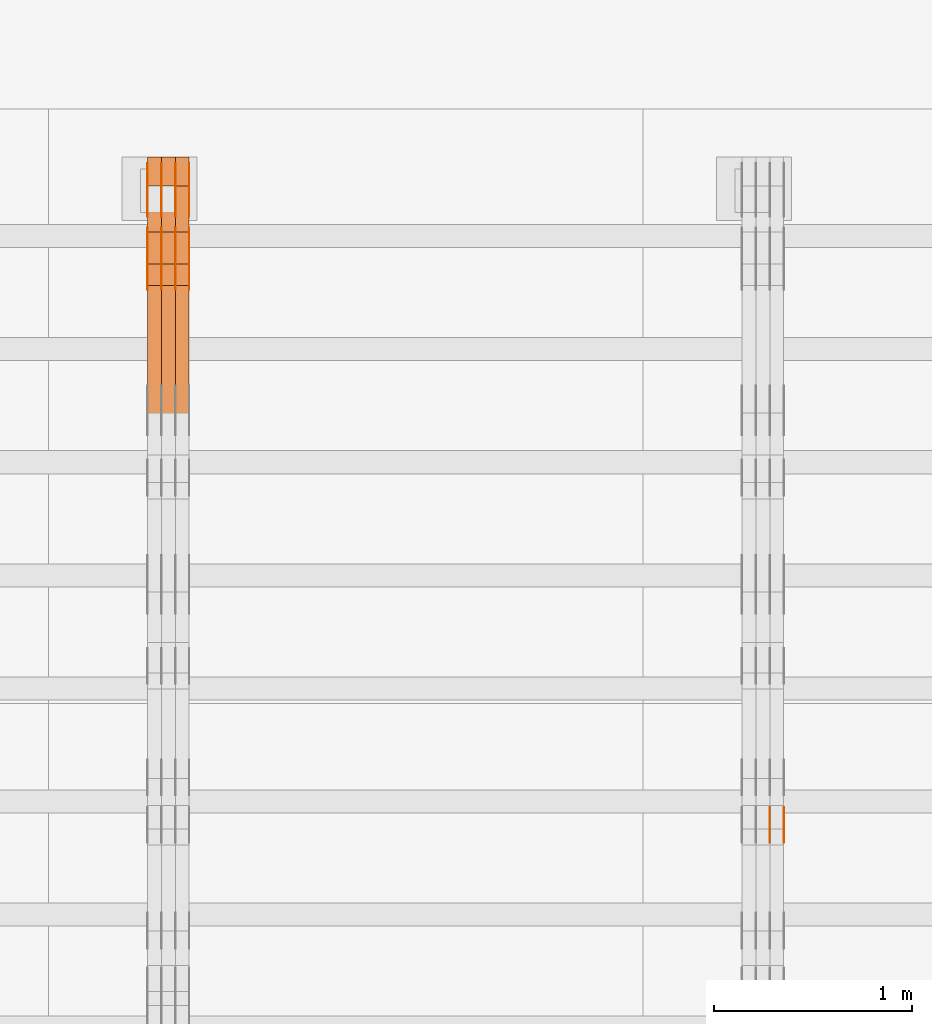
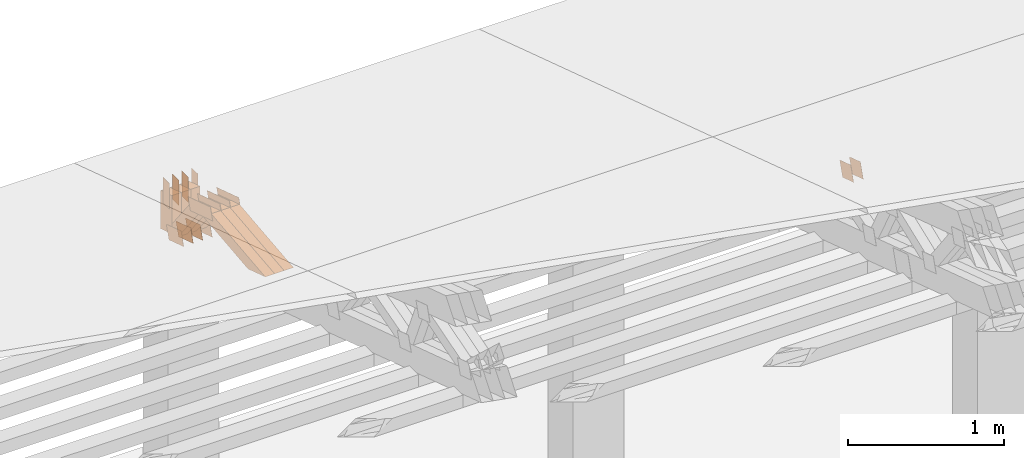
# One storey, part 239 of 385: 29 proxies.
"""IFC2X3 building model written with IfcOpenShell, lengths in millimetres."""

from ifc_helpers import new_model, entity, si_unit, converted_unit, derived_unit, direction, frame, frame_2d, origin, place, context, subcontext, project, spatial, polyline, rectangle, outline, extrude, source, transform, mapped, material, type_object, type_shapes, element, save


model = new_model("IFC2X3")

# Units and contexts
model_context = context("Model", 3, precision=0.01, world=origin(), true_north=direction((6.12303176911189e-17, 1.0)))
body_context = subcontext(model_context, "Body", "Model", "MODEL_VIEW")
ifc_project = project(units=[si_unit("LENGTHUNIT", "METRE", prefix="MILLI"), si_unit("AREAUNIT", "SQUARE_METRE"), si_unit("VOLUMEUNIT", "CUBIC_METRE"), converted_unit("PLANEANGLEUNIT", "DEGREE", entity("IfcRatioMeasure", 0.0174532925199433), si_unit("PLANEANGLEUNIT", "RADIAN"), dimensions=[0, 0, 0, 0, 0, 0, 0]), si_unit("MASSUNIT", "GRAM", prefix="KILO"), derived_unit("MASSDENSITYUNIT", [(si_unit("MASSUNIT", "GRAM", prefix="KILO"), 1), (si_unit("LENGTHUNIT", "METRE"), -3)]), si_unit("TIMEUNIT", "SECOND"), si_unit("FREQUENCYUNIT", "HERTZ"), si_unit("THERMODYNAMICTEMPERATUREUNIT", "DEGREE_CELSIUS"), derived_unit("THERMALTRANSMITTANCEUNIT", [(si_unit("MASSUNIT", "GRAM", prefix="KILO"), 1), (si_unit("THERMODYNAMICTEMPERATUREUNIT", "KELVIN"), -1), (si_unit("TIMEUNIT", "SECOND"), -3)]), derived_unit("VOLUMETRICFLOWRATEUNIT", [(si_unit("LENGTHUNIT", "METRE"), 3), (si_unit("TIMEUNIT", "SECOND"), -1)]), si_unit("ELECTRICCURRENTUNIT", "AMPERE"), si_unit("ELECTRICVOLTAGEUNIT", "VOLT"), si_unit("POWERUNIT", "WATT"), si_unit("FORCEUNIT", "NEWTON", prefix="KILO"), si_unit("ILLUMINANCEUNIT", "LUX"), si_unit("LUMINOUSFLUXUNIT", "LUMEN"), si_unit("LUMINOUSINTENSITYUNIT", "CANDELA"), derived_unit("USERDEFINED", [(si_unit("MASSUNIT", "GRAM", prefix="KILO"), -1), (si_unit("LENGTHUNIT", "METRE"), -2), (si_unit("TIMEUNIT", "SECOND"), 3), (si_unit("LUMINOUSFLUXUNIT", "LUMEN"), 1)]), derived_unit("LINEARVELOCITYUNIT", [(si_unit("LENGTHUNIT", "METRE"), 1), (si_unit("TIMEUNIT", "SECOND"), -1)]), si_unit("PRESSUREUNIT", "PASCAL"), derived_unit("USERDEFINED", [(si_unit("LENGTHUNIT", "METRE"), -2), (si_unit("MASSUNIT", "GRAM", prefix="KILO"), 1), (si_unit("TIMEUNIT", "SECOND"), -2)])], contexts=[model_context])

# Site, building, storey
site_placement = place(None, origin())
site = spatial("IfcSite", under=ifc_project, at=site_placement, CompositionType="ELEMENT")
building_placement = place(site_placement, origin())
building = spatial("IfcBuilding", under=site, at=building_placement, CompositionType="ELEMENT")
storey_placement = place(building_placement, origin())
storey = spatial("IfcBuildingStorey", under=building, at=storey_placement, Name="Default", CompositionType="ELEMENT", Elevation=0.0)

# Proxies
ifc_material_1 = material(Name="IfcSurfaceStyle #368646")
building_element_proxy_type_1 = type_object("IfcBuildingElementProxyType", PredefinedType="NOTDEFINED", material=ifc_material_1)
shared_shape_1 = source(origin(), body_context, "Body", "SweptSolid", [
    extrude(outline(polyline([(-74.9998888504569, -59.9999264677525), (74.999884859074, -59.9999264677525), (74.9998699895559, 59.9999264677525), (-74.999865998173, 59.9999264677525), (-74.9998888504569, -59.9999264677525)])), frame((74.9999170714918, 60.0000016373507, 0.0), z_axis=(0.0, 0.0, 1.0), x_axis=(-1.0, 0.0, 0.0)), (0.0, 0.0, 1.0), 1.3),
])
type_shapes(building_element_proxy_type_1, [shared_shape_1])
proxy_1_placement = place(building_placement, frame((30386.3, 23182.5962361838, 1409.76695322432), z_axis=(-1.0, 0.0, 0.0), x_axis=(0.0, -0.951056516295154, 0.309016994374948)))
element("IfcBuildingElementProxy", 1, at=proxy_1_placement, inside=storey, type_object=building_element_proxy_type_1, material=ifc_material_1, context=body_context, shape_type="MappedRepresentation", body=[
    mapped(shared_shape_1, transform((0.0, 0.0, 0.0), scale=1.0)),
])
ifc_material_2 = material(Name="IfcSurfaceStyle #368589")
building_element_proxy_type_2 = type_object("IfcBuildingElementProxyType", PredefinedType="NOTDEFINED", material=ifc_material_2)
shared_shape_2 = source(origin(), body_context, "Body", "SweptSolid", [
    extrude(outline(polyline([(-74.9998888504569, -59.9999264677525), (74.999884859074, -59.9999264677525), (74.9998699895559, 59.9999264677525), (-74.999865998173, 59.9999264677525), (-74.9998888504569, -59.9999264677525)])), frame((74.9999170714918, 60.0000016373507, 0.0), z_axis=(0.0, 0.0, 1.0), x_axis=(-1.0, 0.0, 0.0)), (0.0, 0.0, 1.0), 1.3),
])
type_shapes(building_element_proxy_type_2, [shared_shape_2])
proxy_2_placement = place(building_placement, frame((30315.0, 23182.5962361838, 1409.76695322432), z_axis=(-1.0, 0.0, 0.0), x_axis=(0.0, -0.951056516295154, 0.309016994374948)))
element("IfcBuildingElementProxy", 2, at=proxy_2_placement, inside=storey, type_object=building_element_proxy_type_2, material=ifc_material_2, context=body_context, shape_type="MappedRepresentation", body=[
    mapped(shared_shape_2, transform((0.0, 0.0, 0.0), scale=1.0)),
])
ifc_material_3 = material(Name="IfcSurfaceStyle #343790")
building_element_proxy_type_3 = type_object("IfcBuildingElementProxyType", PredefinedType="NOTDEFINED", material=ifc_material_3)
shared_shape_3 = source(origin(), body_context, "Body", "SweptSolid", [
    extrude(outline(polyline([(-100.000024997547, -54.0000105875654), (100.000088940899, -54.0000105875654), (99.9999100805868, 54.0000105875654), (-99.9999740239394, 54.0000105875654), (-100.000024997547, -54.0000105875654)])), frame((100.000088940899, 54.0000474633838, 0.0), z_axis=(0.0, 0.0, 1.0), x_axis=(-1.0, 0.0, 0.0)), (0.0, 0.0, 1.0), 1.3),
])
type_shapes(building_element_proxy_type_3, [shared_shape_3])
proxy_3_placement = place(building_placement, frame((27386.3, 26390.6212638563, 73.3227520411355), z_axis=(-1.0, 0.0, 0.0), x_axis=(0.0, -0.951056516295124, 0.309016994375039)))
element("IfcBuildingElementProxy", 3, at=proxy_3_placement, inside=storey, type_object=building_element_proxy_type_3, material=ifc_material_3, context=body_context, shape_type="MappedRepresentation", body=[
    mapped(shared_shape_3, transform((0.0, 0.0, 0.0), scale=1.0)),
])
ifc_material_4 = material(Name="IfcSurfaceStyle #343733")
building_element_proxy_type_4 = type_object("IfcBuildingElementProxyType", PredefinedType="NOTDEFINED", material=ifc_material_4)
shared_shape_4 = source(origin(), body_context, "Body", "SweptSolid", [
    extrude(outline(polyline([(-100.000024997547, -54.0000105875654), (100.000088940899, -54.0000105875654), (99.9999100805868, 54.0000105875654), (-99.9999740239394, 54.0000105875654), (-100.000024997547, -54.0000105875654)])), frame((100.000088940899, 54.0000474633838, 0.0), z_axis=(0.0, 0.0, 1.0), x_axis=(-1.0, 0.0, 0.0)), (0.0, 0.0, 1.0), 1.3),
])
type_shapes(building_element_proxy_type_4, [shared_shape_4])
proxy_4_placement = place(building_placement, frame((27315.0, 26390.6212638563, 73.3227520411355), z_axis=(-1.0, 0.0, 0.0), x_axis=(0.0, -0.951056516295124, 0.309016994375039)))
element("IfcBuildingElementProxy", 4, at=proxy_4_placement, inside=storey, type_object=building_element_proxy_type_4, material=ifc_material_4, context=body_context, shape_type="MappedRepresentation", body=[
    mapped(shared_shape_4, transform((0.0, 0.0, 0.0), scale=1.0)),
])
ifc_material_5 = material(Name="IfcSurfaceStyle #343676")
building_element_proxy_type_5 = type_object("IfcBuildingElementProxyType", PredefinedType="NOTDEFINED", material=ifc_material_5)
shared_shape_5 = source(origin(), body_context, "Body", "SweptSolid", [
    extrude(outline(polyline([(-100.000024997547, -54.0000105875654), (100.000088940899, -54.0000105875654), (99.9999100805868, 54.0000105875654), (-99.9999740239394, 54.0000105875654), (-100.000024997547, -54.0000105875654)])), frame((100.000088940899, 54.0000474633838, 0.0), z_axis=(0.0, 0.0, 1.0), x_axis=(-1.0, 0.0, 0.0)), (0.0, 0.0, 1.0), 1.3),
])
type_shapes(building_element_proxy_type_5, [shared_shape_5])
proxy_5_placement = place(building_placement, frame((27316.3, 26390.6212638563, 73.3227520411355), z_axis=(-1.0, 0.0, 0.0), x_axis=(0.0, -0.951056516295124, 0.309016994375039)))
element("IfcBuildingElementProxy", 5, at=proxy_5_placement, inside=storey, type_object=building_element_proxy_type_5, material=ifc_material_5, context=body_context, shape_type="MappedRepresentation", body=[
    mapped(shared_shape_5, transform((0.0, 0.0, 0.0), scale=1.0)),
])
ifc_material_6 = material(Name="IfcSurfaceStyle #343619")
building_element_proxy_type_6 = type_object("IfcBuildingElementProxyType", PredefinedType="NOTDEFINED", material=ifc_material_6)
shared_shape_6 = source(origin(), body_context, "Body", "SweptSolid", [
    extrude(outline(polyline([(-100.000024997547, -54.0000105875654), (100.000088940899, -54.0000105875654), (99.9999100805868, 54.0000105875654), (-99.9999740239394, 54.0000105875654), (-100.000024997547, -54.0000105875654)])), frame((100.000088940899, 54.0000474633838, 0.0), z_axis=(0.0, 0.0, 1.0), x_axis=(-1.0, 0.0, 0.0)), (0.0, 0.0, 1.0), 1.29999999999998),
])
type_shapes(building_element_proxy_type_6, [shared_shape_6])
proxy_6_placement = place(building_placement, frame((27245.0, 26390.6212638563, 73.3227520411355), z_axis=(-1.0, 0.0, 0.0), x_axis=(0.0, -0.951056516295124, 0.309016994375039)))
element("IfcBuildingElementProxy", 6, at=proxy_6_placement, inside=storey, type_object=building_element_proxy_type_6, material=ifc_material_6, context=body_context, shape_type="MappedRepresentation", body=[
    mapped(shared_shape_6, transform((0.0, 0.0, 0.0), scale=1.0)),
])
ifc_material_7 = material(Name="IfcSurfaceStyle #343562")
building_element_proxy_type_7 = type_object("IfcBuildingElementProxyType", PredefinedType="NOTDEFINED", material=ifc_material_7)
shared_shape_7 = source(origin(), body_context, "Body", "SweptSolid", [
    extrude(outline(polyline([(-100.000024997547, -54.0000105875654), (100.000088940899, -54.0000105875654), (99.9999100805868, 54.0000105875654), (-99.9999740239394, 54.0000105875654), (-100.000024997547, -54.0000105875654)])), frame((100.000088940899, 54.0000474633838, 0.0), z_axis=(0.0, 0.0, 1.0), x_axis=(-1.0, 0.0, 0.0)), (0.0, 0.0, 1.0), 1.29999999999998),
])
type_shapes(building_element_proxy_type_7, [shared_shape_7])
proxy_7_placement = place(building_placement, frame((27246.3, 26390.6212638563, 73.3227520411355), z_axis=(-1.0, 0.0, 0.0), x_axis=(0.0, -0.951056516295124, 0.309016994375039)))
element("IfcBuildingElementProxy", 7, at=proxy_7_placement, inside=storey, type_object=building_element_proxy_type_7, material=ifc_material_7, context=body_context, shape_type="MappedRepresentation", body=[
    mapped(shared_shape_7, transform((0.0, 0.0, 0.0), scale=1.0)),
])
ifc_material_8 = material(Name="IfcSurfaceStyle #343505")
building_element_proxy_type_8 = type_object("IfcBuildingElementProxyType", PredefinedType="NOTDEFINED", material=ifc_material_8)
shared_shape_8 = source(origin(), body_context, "Body", "SweptSolid", [
    extrude(outline(polyline([(-100.000024997547, -54.0000105875654), (100.000088940899, -54.0000105875654), (99.9999100805868, 54.0000105875654), (-99.9999740239394, 54.0000105875654), (-100.000024997547, -54.0000105875654)])), frame((100.000088940899, 54.0000474633838, 0.0), z_axis=(0.0, 0.0, 1.0), x_axis=(-1.0, 0.0, 0.0)), (0.0, 0.0, 1.0), 1.29999999999999),
])
type_shapes(building_element_proxy_type_8, [shared_shape_8])
proxy_8_placement = place(building_placement, frame((27175.0, 26390.6212638563, 73.3227520411355), z_axis=(-1.0, 0.0, 0.0), x_axis=(0.0, -0.951056516295124, 0.309016994375039)))
element("IfcBuildingElementProxy", 8, at=proxy_8_placement, inside=storey, type_object=building_element_proxy_type_8, material=ifc_material_8, context=body_context, shape_type="MappedRepresentation", body=[
    mapped(shared_shape_8, transform((0.0, 0.0, 0.0), scale=1.0)),
])
ifc_material_9 = material(Name="IfcSurfaceStyle #331136")
building_element_proxy_type_9 = type_object("IfcBuildingElementProxyType", PredefinedType="NOTDEFINED", material=ifc_material_9)
shared_shape_9 = source(origin(), body_context, "Body", "SweptSolid", [
    extrude(outline(polyline([(-149.999901061401, -48.0000057587028), (150.000035297123, -48.0000057587028), (149.999910491851, 48.0000057587028), (-150.000044727574, 48.0000057587028), (-149.999901061401, -48.0000057587028)])), frame((150.000035297123, 48.0000632585775, 0.0), z_axis=(0.0, 0.0, 1.0), x_axis=(-1.0, 0.0, 0.0)), (0.0, 0.0, 1.0), 1.29999999999999),
])
type_shapes(building_element_proxy_type_9, [shared_shape_9])
proxy_9_placement = place(building_placement, frame((27386.3, 26115.0176968219, 469.58296924555), z_axis=(-1.0, 0.0, 0.0), x_axis=(0.0, -0.951056516295154, 0.309016994374948)))
element("IfcBuildingElementProxy", 9, at=proxy_9_placement, inside=storey, type_object=building_element_proxy_type_9, material=ifc_material_9, context=body_context, shape_type="MappedRepresentation", body=[
    mapped(shared_shape_9, transform((0.0, 0.0, 0.0), scale=1.0)),
])
ifc_material_10 = material(Name="IfcSurfaceStyle #331079")
building_element_proxy_type_10 = type_object("IfcBuildingElementProxyType", PredefinedType="NOTDEFINED", material=ifc_material_10)
shared_shape_10 = source(origin(), body_context, "Body", "SweptSolid", [
    extrude(outline(polyline([(-149.999901061401, -48.0000057587028), (150.000035297123, -48.0000057587028), (149.999910491851, 48.0000057587028), (-150.000044727574, 48.0000057587028), (-149.999901061401, -48.0000057587028)])), frame((150.000035297123, 48.0000632585775, 0.0), z_axis=(0.0, 0.0, 1.0), x_axis=(-1.0, 0.0, 0.0)), (0.0, 0.0, 1.0), 1.29999999999999),
])
type_shapes(building_element_proxy_type_10, [shared_shape_10])
proxy_10_placement = place(building_placement, frame((27315.0, 26115.0176968219, 469.58296924555), z_axis=(-1.0, 0.0, 0.0), x_axis=(0.0, -0.951056516295154, 0.309016994374948)))
element("IfcBuildingElementProxy", 10, at=proxy_10_placement, inside=storey, type_object=building_element_proxy_type_10, material=ifc_material_10, context=body_context, shape_type="MappedRepresentation", body=[
    mapped(shared_shape_10, transform((0.0, 0.0, 0.0), scale=1.0)),
])
ifc_material_11 = material(Name="IfcSurfaceStyle #331022")
building_element_proxy_type_11 = type_object("IfcBuildingElementProxyType", PredefinedType="NOTDEFINED", material=ifc_material_11)
shared_shape_11 = source(origin(), body_context, "Body", "SweptSolid", [
    extrude(outline(polyline([(-149.999901061401, -48.0000057587028), (150.000035297123, -48.0000057587028), (149.999910491851, 48.0000057587028), (-150.000044727574, 48.0000057587028), (-149.999901061401, -48.0000057587028)])), frame((150.000035297123, 48.0000632585775, 0.0), z_axis=(0.0, 0.0, 1.0), x_axis=(-1.0, 0.0, 0.0)), (0.0, 0.0, 1.0), 1.29999999999999),
])
type_shapes(building_element_proxy_type_11, [shared_shape_11])
proxy_11_placement = place(building_placement, frame((27316.3, 26115.0176968219, 469.58296924555), z_axis=(-1.0, 0.0, 0.0), x_axis=(0.0, -0.951056516295154, 0.309016994374948)))
element("IfcBuildingElementProxy", 11, at=proxy_11_placement, inside=storey, type_object=building_element_proxy_type_11, material=ifc_material_11, context=body_context, shape_type="MappedRepresentation", body=[
    mapped(shared_shape_11, transform((0.0, 0.0, 0.0), scale=1.0)),
])
ifc_material_12 = material(Name="IfcSurfaceStyle #330965")
building_element_proxy_type_12 = type_object("IfcBuildingElementProxyType", PredefinedType="NOTDEFINED", material=ifc_material_12)
shared_shape_12 = source(origin(), body_context, "Body", "SweptSolid", [
    extrude(outline(polyline([(-149.999901061401, -48.0000057587028), (150.000035297123, -48.0000057587028), (149.999910491851, 48.0000057587028), (-150.000044727574, 48.0000057587028), (-149.999901061401, -48.0000057587028)])), frame((150.000035297123, 48.0000632585775, 0.0), z_axis=(0.0, 0.0, 1.0), x_axis=(-1.0, 0.0, 0.0)), (0.0, 0.0, 1.0), 1.29999999999998),
])
type_shapes(building_element_proxy_type_12, [shared_shape_12])
proxy_12_placement = place(building_placement, frame((27245.0, 26115.0176968219, 469.58296924555), z_axis=(-1.0, 0.0, 0.0), x_axis=(0.0, -0.951056516295154, 0.309016994374948)))
element("IfcBuildingElementProxy", 12, at=proxy_12_placement, inside=storey, type_object=building_element_proxy_type_12, material=ifc_material_12, context=body_context, shape_type="MappedRepresentation", body=[
    mapped(shared_shape_12, transform((0.0, 0.0, 0.0), scale=1.0)),
])
ifc_material_13 = material(Name="IfcSurfaceStyle #330908")
building_element_proxy_type_13 = type_object("IfcBuildingElementProxyType", PredefinedType="NOTDEFINED", material=ifc_material_13)
shared_shape_13 = source(origin(), body_context, "Body", "SweptSolid", [
    extrude(outline(polyline([(-149.999901061401, -48.0000057587028), (150.000035297123, -48.0000057587028), (149.999910491851, 48.0000057587028), (-150.000044727574, 48.0000057587028), (-149.999901061401, -48.0000057587028)])), frame((150.000035297123, 48.0000632585775, 0.0), z_axis=(0.0, 0.0, 1.0), x_axis=(-1.0, 0.0, 0.0)), (0.0, 0.0, 1.0), 1.29999999999998),
])
type_shapes(building_element_proxy_type_13, [shared_shape_13])
proxy_13_placement = place(building_placement, frame((27246.3, 26115.0176968219, 469.58296924555), z_axis=(-1.0, 0.0, 0.0), x_axis=(0.0, -0.951056516295154, 0.309016994374948)))
element("IfcBuildingElementProxy", 13, at=proxy_13_placement, inside=storey, type_object=building_element_proxy_type_13, material=ifc_material_13, context=body_context, shape_type="MappedRepresentation", body=[
    mapped(shared_shape_13, transform((0.0, 0.0, 0.0), scale=1.0)),
])
ifc_material_14 = material(Name="IfcSurfaceStyle #330851")
building_element_proxy_type_14 = type_object("IfcBuildingElementProxyType", PredefinedType="NOTDEFINED", material=ifc_material_14)
shared_shape_14 = source(origin(), body_context, "Body", "SweptSolid", [
    extrude(outline(polyline([(-149.999901061401, -48.0000057587028), (150.000035297123, -48.0000057587028), (149.999910491851, 48.0000057587028), (-150.000044727574, 48.0000057587028), (-149.999901061401, -48.0000057587028)])), frame((150.000035297123, 48.0000632585775, 0.0), z_axis=(0.0, 0.0, 1.0), x_axis=(-1.0, 0.0, 0.0)), (0.0, 0.0, 1.0), 1.29999999999998),
])
type_shapes(building_element_proxy_type_14, [shared_shape_14])
proxy_14_placement = place(building_placement, frame((27175.0, 26115.0176968219, 469.58296924555), z_axis=(-1.0, 0.0, 0.0), x_axis=(0.0, -0.951056516295154, 0.309016994374948)))
element("IfcBuildingElementProxy", 14, at=proxy_14_placement, inside=storey, type_object=building_element_proxy_type_14, material=ifc_material_14, context=body_context, shape_type="MappedRepresentation", body=[
    mapped(shared_shape_14, transform((0.0, 0.0, 0.0), scale=1.0)),
])
ifc_material_15 = material(Name="IfcSurfaceStyle #330794")
building_element_proxy_type_15 = type_object("IfcBuildingElementProxyType", PredefinedType="NOTDEFINED", material=ifc_material_15)
shared_shape_15 = source(origin(), body_context, "Body", "SweptSolid", [
    extrude(rectangle(XDim=200.0, YDim=84.0000000000005, at=frame_2d((-2.1316282072803e-14, 1.06581410364015e-14), x_axis=(1.0, 0.0))), frame((100.0, 42.0, 0.0), z_axis=(0.0, 0.0, 1.0), x_axis=(-1.0, 0.0, 0.0)), (0.0, 0.0, 1.0), 1.3),
])
type_shapes(building_element_proxy_type_15, [shared_shape_15])
proxy_15_placement = place(building_placement, frame((27386.3, 26469.5000000002, 518.521545410156), z_axis=(-1.0, 0.0, 0.0), x_axis=(0.0, 0.0, -1.0)))
element("IfcBuildingElementProxy", 15, at=proxy_15_placement, inside=storey, type_object=building_element_proxy_type_15, material=ifc_material_15, context=body_context, shape_type="MappedRepresentation", body=[
    mapped(shared_shape_15, transform((0.0, 0.0, 0.0), scale=1.0)),
])
ifc_material_16 = material(Name="IfcSurfaceStyle #330737")
building_element_proxy_type_16 = type_object("IfcBuildingElementProxyType", PredefinedType="NOTDEFINED", material=ifc_material_16)
shared_shape_16 = source(origin(), body_context, "Body", "SweptSolid", [
    extrude(rectangle(XDim=200.0, YDim=84.0000000000005, at=frame_2d((-2.1316282072803e-14, 1.06581410364015e-14), x_axis=(1.0, 0.0))), frame((100.0, 42.0, 0.0), z_axis=(0.0, 0.0, 1.0), x_axis=(-1.0, 0.0, 0.0)), (0.0, 0.0, 1.0), 1.3),
])
type_shapes(building_element_proxy_type_16, [shared_shape_16])
proxy_16_placement = place(building_placement, frame((27315.0, 26469.5000000002, 518.521545410156), z_axis=(-1.0, 0.0, 0.0), x_axis=(0.0, 0.0, -1.0)))
element("IfcBuildingElementProxy", 16, at=proxy_16_placement, inside=storey, type_object=building_element_proxy_type_16, material=ifc_material_16, context=body_context, shape_type="MappedRepresentation", body=[
    mapped(shared_shape_16, transform((0.0, 0.0, 0.0), scale=1.0)),
])
ifc_material_17 = material(Name="IfcSurfaceStyle #330680")
building_element_proxy_type_17 = type_object("IfcBuildingElementProxyType", PredefinedType="NOTDEFINED", material=ifc_material_17)
shared_shape_17 = source(origin(), body_context, "Body", "SweptSolid", [
    extrude(rectangle(XDim=200.0, YDim=84.0000000000005, at=frame_2d((-2.1316282072803e-14, 1.06581410364015e-14), x_axis=(1.0, 0.0))), frame((100.0, 42.0, 0.0), z_axis=(0.0, 0.0, 1.0), x_axis=(-1.0, 0.0, 0.0)), (0.0, 0.0, 1.0), 1.3),
])
type_shapes(building_element_proxy_type_17, [shared_shape_17])
proxy_17_placement = place(building_placement, frame((27316.3, 26469.5000000002, 518.521545410156), z_axis=(-1.0, 0.0, 0.0), x_axis=(0.0, 0.0, -1.0)))
element("IfcBuildingElementProxy", 17, at=proxy_17_placement, inside=storey, type_object=building_element_proxy_type_17, material=ifc_material_17, context=body_context, shape_type="MappedRepresentation", body=[
    mapped(shared_shape_17, transform((0.0, 0.0, 0.0), scale=1.0)),
])
ifc_material_18 = material(Name="IfcSurfaceStyle #330623")
building_element_proxy_type_18 = type_object("IfcBuildingElementProxyType", PredefinedType="NOTDEFINED", material=ifc_material_18)
shared_shape_18 = source(origin(), body_context, "Body", "SweptSolid", [
    extrude(rectangle(XDim=200.0, YDim=84.0000000000005, at=frame_2d((-2.1316282072803e-14, 1.06581410364015e-14), x_axis=(1.0, 0.0))), frame((100.0, 42.0, 0.0), z_axis=(0.0, 0.0, 1.0), x_axis=(-1.0, 0.0, 0.0)), (0.0, 0.0, 1.0), 1.29999999999998),
])
type_shapes(building_element_proxy_type_18, [shared_shape_18])
proxy_18_placement = place(building_placement, frame((27245.0, 26469.5000000002, 518.521545410156), z_axis=(-1.0, 0.0, 0.0), x_axis=(0.0, 0.0, -1.0)))
element("IfcBuildingElementProxy", 18, at=proxy_18_placement, inside=storey, type_object=building_element_proxy_type_18, material=ifc_material_18, context=body_context, shape_type="MappedRepresentation", body=[
    mapped(shared_shape_18, transform((0.0, 0.0, 0.0), scale=1.0)),
])
ifc_material_19 = material(Name="IfcSurfaceStyle #330566")
building_element_proxy_type_19 = type_object("IfcBuildingElementProxyType", PredefinedType="NOTDEFINED", material=ifc_material_19)
shared_shape_19 = source(origin(), body_context, "Body", "SweptSolid", [
    extrude(rectangle(XDim=200.0, YDim=84.0000000000005, at=frame_2d((-2.1316282072803e-14, 1.06581410364015e-14), x_axis=(1.0, 0.0))), frame((100.0, 42.0, 0.0), z_axis=(0.0, 0.0, 1.0), x_axis=(-1.0, 0.0, 0.0)), (0.0, 0.0, 1.0), 1.29999999999998),
])
type_shapes(building_element_proxy_type_19, [shared_shape_19])
proxy_19_placement = place(building_placement, frame((27246.3, 26469.5000000002, 518.521545410156), z_axis=(-1.0, 0.0, 0.0), x_axis=(0.0, 0.0, -1.0)))
element("IfcBuildingElementProxy", 19, at=proxy_19_placement, inside=storey, type_object=building_element_proxy_type_19, material=ifc_material_19, context=body_context, shape_type="MappedRepresentation", body=[
    mapped(shared_shape_19, transform((0.0, 0.0, 0.0), scale=1.0)),
])
ifc_material_20 = material(Name="IfcSurfaceStyle #330509")
building_element_proxy_type_20 = type_object("IfcBuildingElementProxyType", PredefinedType="NOTDEFINED", material=ifc_material_20)
shared_shape_20 = source(origin(), body_context, "Body", "SweptSolid", [
    extrude(rectangle(XDim=200.0, YDim=84.0000000000005, at=frame_2d((-2.1316282072803e-14, 1.06581410364015e-14), x_axis=(1.0, 0.0))), frame((100.0, 42.0, 0.0), z_axis=(0.0, 0.0, 1.0), x_axis=(-1.0, 0.0, 0.0)), (0.0, 0.0, 1.0), 1.29999999999999),
])
type_shapes(building_element_proxy_type_20, [shared_shape_20])
proxy_20_placement = place(building_placement, frame((27175.0, 26469.5000000002, 518.521545410156), z_axis=(-1.0, 0.0, 0.0), x_axis=(0.0, 0.0, -1.0)))
element("IfcBuildingElementProxy", 20, at=proxy_20_placement, inside=storey, type_object=building_element_proxy_type_20, material=ifc_material_20, context=body_context, shape_type="MappedRepresentation", body=[
    mapped(shared_shape_20, transform((0.0, 0.0, 0.0), scale=1.0)),
])
ifc_material_21 = material(Name="IfcSurfaceStyle #319382")
building_element_proxy_type_21 = type_object("IfcBuildingElementProxyType", Name="T1-W4 319380", PredefinedType="NOTDEFINED", material=ifc_material_21)
shared_shape_21 = source(origin(), body_context, "Body", "SweptSolid", [
    extrude(outline(polyline([(-510.077325435179, -47.4999981284922), (188.854793418912, -47.4999981284922), (294.906688207675, 1.67015383116809e-05), (324.289382923648, 47.499989777723), (-297.973539115057, 47.4999897777231), (-510.077325435179, -47.4999981284922)])), frame((324.289382923648, 47.5000278316275, 0.0), z_axis=(0.0, 0.0, 1.0), x_axis=(-1.0, 0.0, 0.0)), (0.0, 0.0, 1.0), 70.0),
])
type_shapes(building_element_proxy_type_21, [shared_shape_21])
proxy_21_placement = place(building_placement, frame((27385.0, 25996.2241251556, 525.69905884318), z_axis=(-1.0, 0.0, 0.0), x_axis=(0.0, -0.994287125203057, -0.106738524701444)))
element("IfcBuildingElementProxy", 21, at=proxy_21_placement, inside=storey, type_object=building_element_proxy_type_21, material=ifc_material_21, Name="T1-W4", context=body_context, shape_type="MappedRepresentation", body=[
    mapped(shared_shape_21, transform((0.0, 0.0, 0.0), scale=1.0)),
])
ifc_material_22 = material(Name="IfcSurfaceStyle #319316")
building_element_proxy_type_22 = type_object("IfcBuildingElementProxyType", Name="T1-W4 319314", PredefinedType="NOTDEFINED", material=ifc_material_22)
shared_shape_22 = source(origin(), body_context, "Body", "SweptSolid", [
    extrude(outline(polyline([(-510.077325435179, -47.4999981284922), (188.854793418912, -47.4999981284922), (294.906688207675, 1.67015383116809e-05), (324.289382923648, 47.499989777723), (-297.973539115057, 47.4999897777231), (-510.077325435179, -47.4999981284922)])), frame((324.289382923648, 47.5000278316275, 0.0), z_axis=(0.0, 0.0, 1.0), x_axis=(-1.0, 0.0, 0.0)), (0.0, 0.0, 1.0), 70.0),
])
type_shapes(building_element_proxy_type_22, [shared_shape_22])
proxy_22_placement = place(building_placement, frame((27315.0, 25996.2241251556, 525.69905884318), z_axis=(-1.0, 0.0, 0.0), x_axis=(0.0, -0.994287125203057, -0.106738524701444)))
element("IfcBuildingElementProxy", 22, at=proxy_22_placement, inside=storey, type_object=building_element_proxy_type_22, material=ifc_material_22, Name="T1-W4", context=body_context, shape_type="MappedRepresentation", body=[
    mapped(shared_shape_22, transform((0.0, 0.0, 0.0), scale=1.0)),
])
ifc_material_23 = material(Name="IfcSurfaceStyle #319250")
building_element_proxy_type_23 = type_object("IfcBuildingElementProxyType", Name="T1-W4 319248", PredefinedType="NOTDEFINED", material=ifc_material_23)
shared_shape_23 = source(origin(), body_context, "Body", "SweptSolid", [
    extrude(outline(polyline([(-510.077325435179, -47.4999981284922), (188.854793418912, -47.4999981284922), (294.906688207675, 1.67015383116809e-05), (324.289382923648, 47.499989777723), (-297.973539115057, 47.4999897777231), (-510.077325435179, -47.4999981284922)])), frame((324.289382923648, 47.5000278316275, 0.0), z_axis=(0.0, 0.0, 1.0), x_axis=(-1.0, 0.0, 0.0)), (0.0, 0.0, 1.0), 70.0),
])
type_shapes(building_element_proxy_type_23, [shared_shape_23])
proxy_23_placement = place(building_placement, frame((27245.0, 25996.2241251556, 525.69905884318), z_axis=(-1.0, 0.0, 0.0), x_axis=(0.0, -0.994287125203057, -0.106738524701444)))
element("IfcBuildingElementProxy", 23, at=proxy_23_placement, inside=storey, type_object=building_element_proxy_type_23, material=ifc_material_23, Name="T1-W4", context=body_context, shape_type="MappedRepresentation", body=[
    mapped(shared_shape_23, transform((0.0, 0.0, 0.0), scale=1.0)),
])
ifc_material_24 = material(Name="IfcSurfaceStyle #318986")
building_element_proxy_type_24 = type_object("IfcBuildingElementProxyType", Name="T1-W21 318984", PredefinedType="NOTDEFINED", material=ifc_material_24)
shared_shape_24 = source(origin(), body_context, "Body", "SweptSolid", [
    extrude(outline(polyline([(-209.199362597501, -47.5000308982766), (168.813164734153, -47.5000308982766), (229.900717355638, -2.18385470334148e-05), (159.828709317766, 47.5000418175501), (-349.343228810055, 47.5000418175502), (-209.199362597501, -47.5000308982766)])), frame((229.900720156071, 47.5000418175501, 0.0), z_axis=(0.0, 0.0, 1.0), x_axis=(-1.0, 0.0, 0.0)), (0.0, 0.0, 1.0), 70.0),
])
type_shapes(building_element_proxy_type_24, [shared_shape_24])
proxy_24_placement = place(building_placement, frame((27385.0, 26317.5019908272, 112.518372832984), z_axis=(-1.0, 0.0, 0.0), x_axis=(0.0, -0.613839629272042, 0.789430750310097)))
element("IfcBuildingElementProxy", 24, at=proxy_24_placement, inside=storey, type_object=building_element_proxy_type_24, material=ifc_material_24, Name="T1-W21", context=body_context, shape_type="MappedRepresentation", body=[
    mapped(shared_shape_24, transform((0.0, 0.0, 0.0), scale=1.0)),
])
ifc_material_25 = material(Name="IfcSurfaceStyle #318920")
building_element_proxy_type_25 = type_object("IfcBuildingElementProxyType", Name="T1-W21 318918", PredefinedType="NOTDEFINED", material=ifc_material_25)
shared_shape_25 = source(origin(), body_context, "Body", "SweptSolid", [
    extrude(outline(polyline([(-209.199362597501, -47.5000308982766), (168.813164734153, -47.5000308982766), (229.900717355638, -2.18385470334148e-05), (159.828709317766, 47.5000418175501), (-349.343228810055, 47.5000418175502), (-209.199362597501, -47.5000308982766)])), frame((229.900720156071, 47.5000418175501, 0.0), z_axis=(0.0, 0.0, 1.0), x_axis=(-1.0, 0.0, 0.0)), (0.0, 0.0, 1.0), 70.0),
])
type_shapes(building_element_proxy_type_25, [shared_shape_25])
proxy_25_placement = place(building_placement, frame((27315.0, 26317.5019908272, 112.518372832984), z_axis=(-1.0, 0.0, 0.0), x_axis=(0.0, -0.613839629272042, 0.789430750310097)))
element("IfcBuildingElementProxy", 25, at=proxy_25_placement, inside=storey, type_object=building_element_proxy_type_25, material=ifc_material_25, Name="T1-W21", context=body_context, shape_type="MappedRepresentation", body=[
    mapped(shared_shape_25, transform((0.0, 0.0, 0.0), scale=1.0)),
])
ifc_material_26 = material(Name="IfcSurfaceStyle #318854")
building_element_proxy_type_26 = type_object("IfcBuildingElementProxyType", Name="T1-W21 318852", PredefinedType="NOTDEFINED", material=ifc_material_26)
shared_shape_26 = source(origin(), body_context, "Body", "SweptSolid", [
    extrude(outline(polyline([(-209.199362597501, -47.5000308982766), (168.813164734153, -47.5000308982766), (229.900717355638, -2.18385470334148e-05), (159.828709317766, 47.5000418175501), (-349.343228810055, 47.5000418175502), (-209.199362597501, -47.5000308982766)])), frame((229.900720156071, 47.5000418175501, 0.0), z_axis=(0.0, 0.0, 1.0), x_axis=(-1.0, 0.0, 0.0)), (0.0, 0.0, 1.0), 70.0),
])
type_shapes(building_element_proxy_type_26, [shared_shape_26])
proxy_26_placement = place(building_placement, frame((27245.0, 26317.5019908272, 112.518372832984), z_axis=(-1.0, 0.0, 0.0), x_axis=(0.0, -0.613839629272042, 0.789430750310097)))
element("IfcBuildingElementProxy", 26, at=proxy_26_placement, inside=storey, type_object=building_element_proxy_type_26, material=ifc_material_26, Name="T1-W21", context=body_context, shape_type="MappedRepresentation", body=[
    mapped(shared_shape_26, transform((0.0, 0.0, 0.0), scale=1.0)),
])
ifc_material_27 = material(Name="IfcSurfaceStyle #318419")
building_element_proxy_type_27 = type_object("IfcBuildingElementProxyType", Name="T1-E2 318417", PredefinedType="NOTDEFINED", material=ifc_material_27)
shared_shape_27 = source(origin(), body_context, "Body", "SweptSolid", [
    extrude(outline(polyline([(-126.644535064697, -72.4999999999998), (173.757884979248, -72.4999999999998), (126.644542694092, 72.4999999999998), (-173.757892608642, 72.4999999999998), (-126.644535064697, -72.4999999999998)])), frame((173.757890653796, 72.5000000000002, 0.0), z_axis=(0.0, 0.0, 1.0), x_axis=(-1.0, 0.0, 0.0)), (0.0, 0.0, 1.0), 70.0),
])
type_shapes(building_element_proxy_type_27, [shared_shape_27])
proxy_27_placement = place(building_placement, frame((27385.0, 26500.0, 442.078222227283), z_axis=(-1.0, 0.0, 0.0), x_axis=(0.0, 0.0, -1.0)))
element("IfcBuildingElementProxy", 27, at=proxy_27_placement, inside=storey, type_object=building_element_proxy_type_27, material=ifc_material_27, Name="T1-E2", context=body_context, shape_type="MappedRepresentation", body=[
    mapped(shared_shape_27, transform((0.0, 0.0, 0.0), scale=1.0)),
])
ifc_material_28 = material(Name="IfcSurfaceStyle #318362")
building_element_proxy_type_28 = type_object("IfcBuildingElementProxyType", Name="T1-E2 318360", PredefinedType="NOTDEFINED", material=ifc_material_28)
shared_shape_28 = source(origin(), body_context, "Body", "SweptSolid", [
    extrude(outline(polyline([(-126.644535064697, -72.4999999999998), (173.757884979248, -72.4999999999998), (126.644542694092, 72.4999999999998), (-173.757892608642, 72.4999999999998), (-126.644535064697, -72.4999999999998)])), frame((173.757890653796, 72.5000000000002, 0.0), z_axis=(0.0, 0.0, 1.0), x_axis=(-1.0, 0.0, 0.0)), (0.0, 0.0, 1.0), 70.0),
])
type_shapes(building_element_proxy_type_28, [shared_shape_28])
proxy_28_placement = place(building_placement, frame((27315.0, 26500.0, 442.078222227283), z_axis=(-1.0, 0.0, 0.0), x_axis=(0.0, 0.0, -1.0)))
element("IfcBuildingElementProxy", 28, at=proxy_28_placement, inside=storey, type_object=building_element_proxy_type_28, material=ifc_material_28, Name="T1-E2", context=body_context, shape_type="MappedRepresentation", body=[
    mapped(shared_shape_28, transform((0.0, 0.0, 0.0), scale=1.0)),
])
ifc_material_29 = material(Name="IfcSurfaceStyle #318305")
building_element_proxy_type_29 = type_object("IfcBuildingElementProxyType", Name="T1-E2 318303", PredefinedType="NOTDEFINED", material=ifc_material_29)
shared_shape_29 = source(origin(), body_context, "Body", "SweptSolid", [
    extrude(outline(polyline([(-126.644535064697, -72.4999999999998), (173.757884979248, -72.4999999999998), (126.644542694092, 72.4999999999998), (-173.757892608642, 72.4999999999998), (-126.644535064697, -72.4999999999998)])), frame((173.757890653796, 72.5000000000002, 0.0), z_axis=(0.0, 0.0, 1.0), x_axis=(-1.0, 0.0, 0.0)), (0.0, 0.0, 1.0), 70.0),
])
type_shapes(building_element_proxy_type_29, [shared_shape_29])
proxy_29_placement = place(building_placement, frame((27245.0, 26500.0, 442.078222227283), z_axis=(-1.0, 0.0, 0.0), x_axis=(0.0, 0.0, -1.0)))
element("IfcBuildingElementProxy", 29, at=proxy_29_placement, inside=storey, type_object=building_element_proxy_type_29, material=ifc_material_29, Name="T1-E2", context=body_context, shape_type="MappedRepresentation", body=[
    mapped(shared_shape_29, transform((0.0, 0.0, 0.0), scale=1.0)),
])

save(model, "model.ifc")
